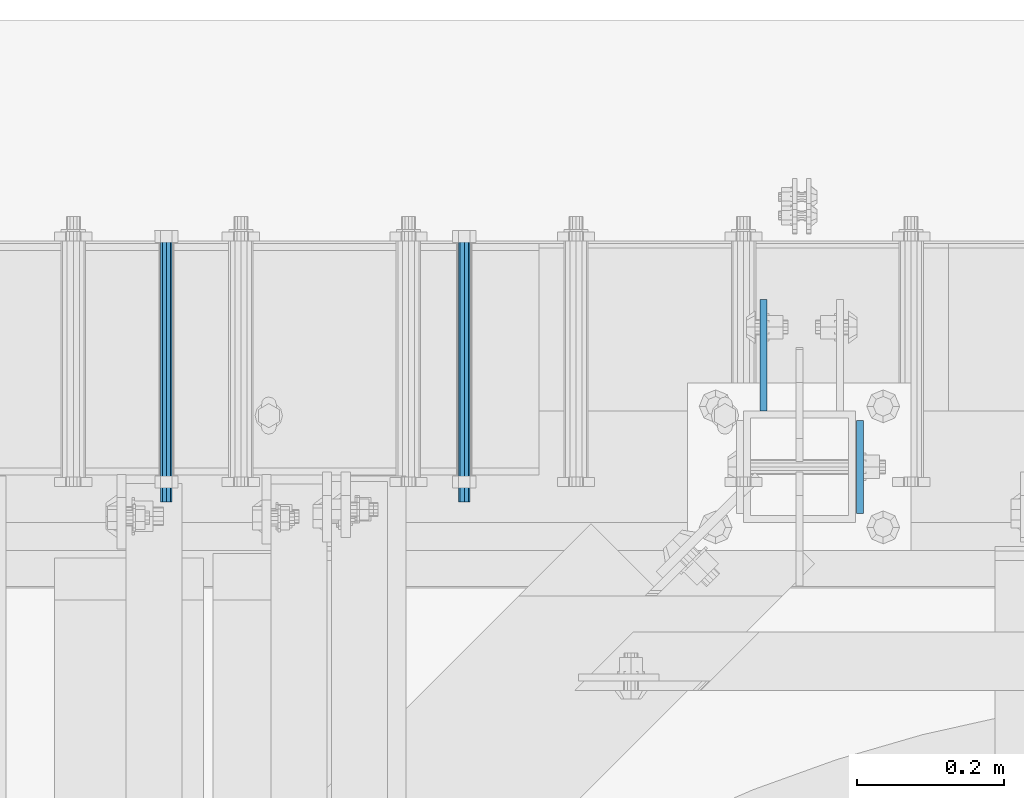
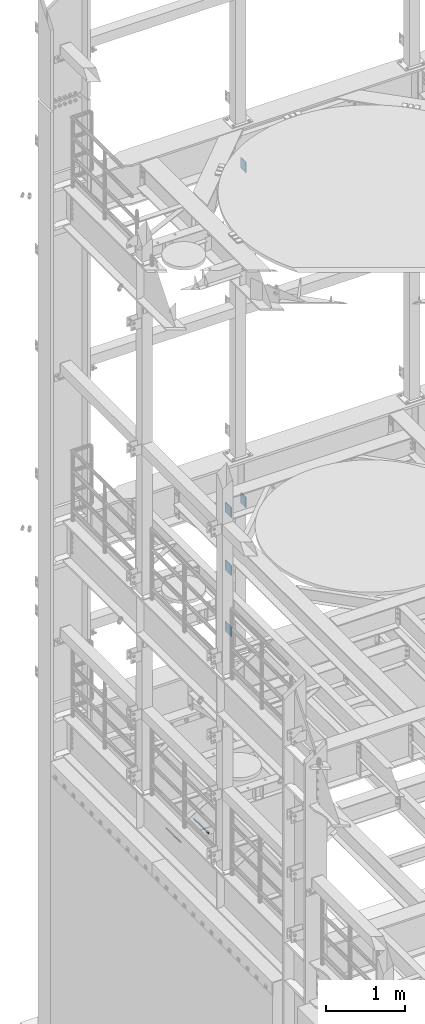
# One storey, part 1320 of 1876: 7 beams, 5 elements without a shape of their own.
"""IFC2X3 building model written with IfcOpenShell, lengths in millimetres."""

import ifcopenshell
import ifcopenshell.guid

model = None  # the IFC model being written
_history = None  # IfcOwnerHistory: only IFC2X3 demands one
_inside = {}  # id of a spatial element -> (the spatial element, [elements in it])
_under = {}  # id of a project, library or spatial element -> (it, [spatial elements below it])
_declared = {}  # id of a project -> (the project, [libraries it declares])
_typed = {}  # id of a type object -> (the type object, [elements of that type])
_made_of = {}  # id of a material, layer set ... -> (it, [elements and type objects made of it])


def new_model(schema):
    """Start an empty IFC model of exactly this schema.

    Asked for "IFC4X3", IfcOpenShell would pick the latest addendum, in which some entities
    have other attributes; the version numbers below select the first issue.
    IFC2X3 requires an IfcOwnerHistory on every rooted entity: one is made here for all.
    """
    global model, _history
    if schema == "IFC4X3":
        model = ifcopenshell.file(schema_version=(4, 3, 0, 0))
    else:
        model = ifcopenshell.file(schema=schema)
    _inside.clear()
    _under.clear()
    _declared.clear()
    _typed.clear()
    _made_of.clear()
    _history = None
    if model.schema == "IFC2X3":
        org = make("IfcOrganization", Name="unknown")
        user = make(
            "IfcPersonAndOrganization",
            ThePerson=make("IfcPerson", FamilyName="unknown"),
            TheOrganization=org,
        )
        app = make(
            "IfcApplication",
            ApplicationDeveloper=org,
            Version="unknown",
            ApplicationFullName="unknown",
            ApplicationIdentifier="unknown",
        )
        _history = make(
            "IfcOwnerHistory",
            OwningUser=user,
            OwningApplication=app,
            ChangeAction="ADDED",
            CreationDate=0,
        )
    return model


def make(cls, **values):
    """One entity of the class cls with the attributes given. An attribute that is None is left unset."""
    return model.create_entity(
        cls, **{name: value for name, value in values.items() if value is not None}
    )


def rooted(cls, **values):
    """An entity with a GlobalId (a new one), such as an element, a storey or a relation."""
    return make(cls, GlobalId=ifcopenshell.guid.new(), OwnerHistory=_history, **values)


def si_unit(unit_type, name, prefix=None):
    """IfcSIUnit, for example si_unit("LENGTHUNIT", "METRE", prefix="MILLI")."""
    return make("IfcSIUnit", UnitType=unit_type, Prefix=prefix, Name=name)


def assignment(units):
    """IfcUnitAssignment: the units of a project."""
    return None if units is None else make("IfcUnitAssignment", Units=units)


def point(xyz):
    """IfcCartesianPoint."""
    return None if xyz is None else make("IfcCartesianPoint", Coordinates=xyz)


def direction(xyz):
    """IfcDirection."""
    return None if xyz is None else make("IfcDirection", DirectionRatios=xyz)


def frame(location, z_axis=None, x_axis=None):
    """IfcAxis2Placement3D, a coordinate frame: its origin and axes. An axis left out is left unset."""
    return make(
        "IfcAxis2Placement3D",
        Location=point(location),
        Axis=direction(z_axis),
        RefDirection=direction(x_axis),
    )


def origin_with_axes():
    """The frame at (0, 0, 0) with the z axis (0, 0, 1) and the x axis (1, 0, 0) written out."""
    return frame((0.0, 0.0, 0.0), z_axis=(0.0, 0.0, 1.0), x_axis=(1.0, 0.0, 0.0))


def place(relative_to, where):
    """IfcLocalPlacement: puts the frame where relative to a parent placement (None: the world)."""
    return make(
        "IfcLocalPlacement", PlacementRelTo=relative_to, RelativePlacement=where
    )


def context(
    kind, dimensions, precision=None, world=None, true_north=None, identifier=None
):
    """IfcGeometricRepresentationContext, for example the 3D "Model" context."""
    return make(
        "IfcGeometricRepresentationContext",
        ContextIdentifier=identifier,
        ContextType=kind,
        CoordinateSpaceDimension=dimensions,
        Precision=precision,
        WorldCoordinateSystem=world,
        TrueNorth=true_north,
    )


def subcontext(parent, identifier, kind, view, scale=None):
    """IfcGeometricRepresentationSubContext, for example "Body" below "Model"."""
    return make(
        "IfcGeometricRepresentationSubContext",
        ContextIdentifier=identifier,
        ContextType=kind,
        ParentContext=parent,
        TargetScale=scale,
        TargetView=view,
    )


def project(units=None, contexts=None):
    """IfcProject with its units and contexts."""
    return rooted(
        "IfcProject",
        Name="project",
        RepresentationContexts=contexts,
        UnitsInContext=assignment(units),
    )


def spatial(cls, under=None, at=None, **own):
    """A site, building, storey or space (cls), placed at a placement, below another one or the project."""
    s = rooted(cls, ObjectPlacement=at, **own)
    if under is not None:
        _under.setdefault(under.id(), (under, []))[1].append(s)
    return s


def faces_of(points, faces, orient=None, outer=None):
    """IfcFace entities. A face is a list of loops; a loop is a list of indices into points, from 0.

    orient and outer hold one flag for each loop. By default every Orientation is true, the
    first loop of a face is its IfcFaceOuterBound and the others are IfcFaceBound.
    """
    made = []
    for i, loops in enumerate(faces):
        bounds = []
        for j, loop in enumerate(loops):
            is_outer = j == 0 if outer is None else outer[i][j]
            bounds.append(
                make(
                    "IfcFaceOuterBound" if is_outer else "IfcFaceBound",
                    Bound=make("IfcPolyLoop", Polygon=[points[k] for k in loop]),
                    Orientation=True if orient is None else orient[i][j],
                )
            )
        made.append(make("IfcFace", Bounds=bounds))
    return made


def faceted_brep(points, faces, orient=None, outer=None, voids=None):
    """IfcFacetedBrep: a solid bounded by flat faces; with voids (closed shells), ...WithVoids."""
    shared = [point(p) for p in points]
    hull = make("IfcClosedShell", CfsFaces=faces_of(shared, faces, orient, outer))
    if voids is None:
        return make("IfcFacetedBrep", Outer=hull)
    return make(
        "IfcFacetedBrepWithVoids",
        Outer=hull,
        Voids=[
            make(cls, CfsFaces=faces_of(shared, fs, o, b)) for cls, fs, o, b in voids
        ],
    )


def shape(context_of_items, identifier, shape_type, items):
    """IfcShapeRepresentation: the items that make up one representation, for example the "Body"."""
    return make(
        "IfcShapeRepresentation",
        ContextOfItems=context_of_items,
        RepresentationIdentifier=identifier,
        RepresentationType=shape_type,
        Items=items,
    )


def material(Name=None, Category=None):
    """IfcMaterial."""
    return make("IfcMaterial", Name=Name, Category=Category)


def made_of(thing, what):
    """Note that an element or type object is made of a material, layer set ...; save() writes the relation."""
    if what is not None:
        _made_of.setdefault(what.id(), (what, []))[1].append(thing)
    return thing


def type_object(cls, material=None, **own):
    """A type object (cls), such as IfcWallType, which elements share."""
    return made_of(rooted(cls, **own), material)


def element(
    cls,
    number,
    at=None,
    inside=None,
    cuts=None,
    type_object=None,
    material=None,
    context=None,
    identifier="Body",
    shape_type=None,
    held_by="IfcProductDefinitionShape",
    body=None,
    shapes=None,
    **own,
):
    """One element of the class cls, such as IfcWall. Its Tag is "e" and its number.

    at: its placement. inside: the storey or other place that contains it. cuts: it is an
    opening in that element (IfcRelVoidsElement). A single representation is given by context,
    identifier, shape_type and body (its items); several are given by shapes. held_by: the class
    of the entity that holds the representations. save() writes the other relations.
    """
    e = rooted(cls, Tag="e%d" % number, ObjectPlacement=at, **own)
    if body is not None:
        shapes = [shape(context, identifier, shape_type, body)]
    if shapes is not None:
        e.Representation = make(held_by, Representations=shapes)
    if inside is not None:
        _inside.setdefault(inside.id(), (inside, []))[1].append(e)
    if cuts is not None:
        rooted(
            "IfcRelVoidsElement", RelatingBuildingElement=cuts, RelatedOpeningElement=e
        )
    if type_object is not None:
        _typed.setdefault(type_object.id(), (type_object, []))[1].append(e)
    return made_of(e, material)


def aggregate(whole, parts):
    """IfcRelAggregates: a whole, such as a stair, and the parts it consists of."""
    return rooted("IfcRelAggregates", RelatingObject=whole, RelatedObjects=parts)


def save(model, path):
    """Write the relations noted so far, then the file.

    IfcRelAggregates (storeys below a building ...), IfcRelContainedInSpatialStructure (elements
    in a storey), IfcRelDefinesByType, IfcRelAssociatesMaterial and IfcRelDeclares: one each for
    every whole, place, type object, material and project.
    """
    for whole, parts in _under.values():
        aggregate(whole, parts)
    for where, things in _inside.values():
        rooted(
            "IfcRelContainedInSpatialStructure",
            RelatedElements=things,
            RelatingStructure=where,
        )
    for kind, things in _typed.values():
        rooted("IfcRelDefinesByType", RelatedObjects=things, RelatingType=kind)
    for what, things in _made_of.values():
        rooted("IfcRelAssociatesMaterial", RelatedObjects=things, RelatingMaterial=what)
    for by, libraries in _declared.values():
        rooted("IfcRelDeclares", RelatingContext=by, RelatedDefinitions=libraries)
    model.write(path)


model = new_model("IFC2X3")

# Units and contexts
model_context = context("Model", 3, precision=1e-05, world=origin_with_axes())
body_context = subcontext(model_context, "Body", "Model", "MODEL_VIEW")
ifc_project = project(units=[si_unit("LENGTHUNIT", "METRE", prefix="MILLI"), si_unit("AREAUNIT", "SQUARE_METRE"), si_unit("VOLUMEUNIT", "CUBIC_METRE"), si_unit("MASSUNIT", "GRAM", prefix="KILO"), si_unit("TIMEUNIT", "SECOND"), si_unit("PLANEANGLEUNIT", "RADIAN"), si_unit("SOLIDANGLEUNIT", "STERADIAN"), si_unit("THERMODYNAMICTEMPERATUREUNIT", "DEGREE_CELSIUS"), si_unit("LUMINOUSINTENSITYUNIT", "LUMEN")], contexts=[model_context])

# Site, building, storey
site_placement = place(None, origin_with_axes())
site = spatial("IfcSite", under=ifc_project, at=site_placement, CompositionType="ELEMENT")
building_placement = place(site_placement, origin_with_axes())
building = spatial("IfcBuilding", under=site, at=building_placement, Name="Undefined", CompositionType="ELEMENT")
storey_placement = place(building_placement, origin_with_axes())
storey = spatial("IfcBuildingStorey", under=building, at=storey_placement, Name="Undefined", CompositionType="ELEMENT", Elevation=0.0)

# Assembly, beams
assembly_1_placement = place(storey_placement, origin_with_axes())
assembly_1 = element("IfcElementAssembly", 1, at=assembly_1_placement, inside=storey, Name="FRAME", AssemblyPlace="NOTDEFINED", PredefinedType="RIGID_FRAME")
ifc_material = material(Name="STEEL/A36")
beam_type_1 = type_object("IfcBeamType", PredefinedType="NOTDEFINED")
beam_1_placement = place(assembly_1_placement, frame((2490.7762944527, 13792.2, 7226.3), z_axis=(0.0, 0.0, -1.0), x_axis=(0.0, 1.0, 0.0)))
beam_1 = element("IfcBeam", 2, at=beam_1_placement, type_object=beam_type_1, material=ifc_material, Name="PLATE", context=body_context, shape_type="Brep", body=[
    faceted_brep([(0.0, 4.76249999999982, -76.1999999999998), (3.63797880709171e-12, 4.76249999999982, 76.1999969482422), (152.399993896484, 4.76250000000073, 76.1999969482422), (152.4, 4.76249999999982, -76.1999999999998), (3.63797880709171e-12, -4.76249999999982, 76.1999969482422), (152.399993896484, -4.76250000000073, 76.1999969482422), (0.0, -4.76249999999982, -76.1999999999998), (152.4, -4.76249999999982, -76.1999999999998)], [[[0, 1, 2, 3]], [[4, 5, 2, 1]], [[4, 6, 7, 5]], [[6, 0, 3, 7]], [[5, 7, 3, 2]], [[6, 4, 1, 0]]]),
])
beam_2_placement = place(assembly_1_placement, frame((2490.7762944527, 13792.2, 6330.95), z_axis=(0.0, 0.0, -1.0), x_axis=(0.0, 1.0, 0.0)))
beam_2 = element("IfcBeam", 3, at=beam_2_placement, type_object=beam_type_1, material=ifc_material, Name="PLATE", context=body_context, shape_type="Brep", body=[
    faceted_brep([(0.0, 4.76249999999982, -76.1999999999998), (3.63797880709171e-12, 4.76249999999982, 76.1999969482422), (152.399993896484, 4.76250000000073, 76.1999969482422), (152.4, 4.76249999999982, -76.1999999999998), (3.63797880709171e-12, -4.76249999999982, 76.1999969482422), (152.399993896484, -4.76250000000073, 76.1999969482422), (0.0, -4.76249999999982, -76.1999999999998), (152.4, -4.76249999999982, -76.1999999999998)], [[[0, 1, 2, 3]], [[4, 5, 2, 1]], [[4, 6, 7, 5]], [[6, 0, 3, 7]], [[5, 7, 3, 2]], [[6, 4, 1, 0]]]),
])
beam_3_placement = place(assembly_1_placement, frame((2490.7762944527, 13792.2, 5384.8), z_axis=(0.0, 0.0, -1.0), x_axis=(0.0, 1.0, 0.0)))
beam_3 = element("IfcBeam", 4, at=beam_3_placement, type_object=beam_type_1, material=ifc_material, Name="PLATE", context=body_context, shape_type="Brep", body=[
    faceted_brep([(0.0, 4.76249999999982, -76.1999999999998), (3.63797880709171e-12, 4.76249999999982, 76.1999969482422), (152.399993896484, 4.76250000000073, 76.1999969482422), (152.4, 4.76249999999982, -76.1999999999998), (3.63797880709171e-12, -4.76249999999982, 76.1999969482422), (152.399993896484, -4.76250000000073, 76.1999969482422), (0.0, -4.76249999999982, -76.1999999999998), (152.4, -4.76249999999982, -76.1999999999998)], [[[0, 1, 2, 3]], [[4, 5, 2, 1]], [[4, 6, 7, 5]], [[6, 0, 3, 7]], [[5, 7, 3, 2]], [[6, 4, 1, 0]]]),
])
aggregate(assembly_1, [beam_1, beam_2, beam_3])

# Assembly, beam
assembly_2_placement = place(storey_placement, origin_with_axes())
assembly_2 = element("IfcElementAssembly", 5, at=assembly_2_placement, inside=storey, Name="BEAM", AssemblyPlace="NOTDEFINED", PredefinedType="RIGID_FRAME")
beam_type_2 = type_object("IfcBeamType", PredefinedType="NOTDEFINED")
beam_4_placement = place(assembly_2_placement, frame((2622.55, 13779.5, 7423.15), z_axis=(0.0, 0.0, -1.0), x_axis=(0.0, -1.0, 0.0)))
beam_4 = element("IfcBeam", 6, at=beam_4_placement, type_object=beam_type_2, material=ifc_material, Name="PLATE", context=body_context, shape_type="Brep", body=[
    faceted_brep([(0.0, 4.76249999999982, -82.5499999999993), (0.0, 4.76249999999982, 82.5499999999993), (127.0, 4.76249999999982, 82.5499999999993), (127.0, 4.76249999999982, -82.5499999999993), (0.0, -4.76249999999982, 82.5499999999993), (127.0, -4.76249999999982, 82.5499999999993), (0.0, -4.76249999999982, -82.5499999999993), (127.0, -4.76249999999982, -82.5499999999993)], [[[0, 1, 2, 3]], [[1, 4, 5, 2]], [[4, 6, 7, 5]], [[6, 0, 3, 7]], [[5, 7, 3, 2]], [[6, 4, 1, 0]]]),
])
aggregate(assembly_2, [beam_4])

assembly_3_placement = place(storey_placement, origin_with_axes())
assembly_3 = element("IfcElementAssembly", 7, at=assembly_3_placement, inside=storey, Name="BEAM", AssemblyPlace="NOTDEFINED", PredefinedType="RIGID_FRAME")
beam_5_placement = place(assembly_3_placement, frame((2622.55, 13779.5, 12598.4), z_axis=(0.0, 0.0, -1.0), x_axis=(0.0, -1.0, 0.0)))
beam_5 = element("IfcBeam", 8, at=beam_5_placement, type_object=beam_type_2, material=ifc_material, Name="PLATE", context=body_context, shape_type="Brep", body=[
    faceted_brep([(0.0, 4.76249999999982, -82.5499999999993), (0.0, 4.76249999999982, 82.5499999999993), (127.0, 4.76249999999982, 82.5499999999993), (127.0, 4.76249999999982, -82.5499999999993), (0.0, -4.76249999999982, 82.5499999999993), (127.0, -4.76249999999982, 82.5499999999993), (0.0, -4.76249999999982, -82.5499999999993), (127.0, -4.76249999999982, -82.5499999999993)], [[[0, 1, 2, 3]], [[1, 4, 5, 2]], [[4, 6, 7, 5]], [[6, 0, 3, 7]], [[5, 7, 3, 2]], [[6, 4, 1, 0]]]),
])
aggregate(assembly_3, [beam_5])

assembly_4_placement = place(storey_placement, origin_with_axes())
assembly_4 = element("IfcElementAssembly", 9, at=assembly_4_placement, inside=storey, Name="ANCHOR_BOLT", AssemblyPlace="NOTDEFINED", PredefinedType="RIGID_FRAME")
beam_type_3 = type_object("IfcBeamType", PredefinedType="NOTDEFINED")
beam_6_placement = place(assembly_4_placement, frame((1676.40979190826, 13668.3750030189, 2493.96240234375), z_axis=(0.0, 0.0, 1.0), x_axis=(-2.91149999876944e-05, 0.999999999576158, 0.0)))
beam_6 = element("IfcBeam", 10, at=beam_6_placement, type_object=beam_type_3, material=ifc_material, Name="ANCHOR_BOLT", context=body_context, shape_type="Brep", body=[
    faceted_brep([(0.0, -7.9375, 0.0), (0.0, -5.61266007566822, -5.61266007566883), (369.887490732475, -5.61266007567792, -5.61266007566837), (369.887490732477, -7.93750000000978, 0.0), (0.0, 0.0, -7.9375), (369.88749073247, -9.54969436861575e-12, -7.9375), (0.0, 5.61266007566822, -5.61266007566883), (369.887490732464, 5.6126600756586, -5.61266007566837), (0.0, 7.9375, 0.0), (369.887490732463, 7.93749999999045, 0.0), (0.0, 5.61266007566822, 5.61266007566883), (369.887490732464, 5.6126600756586, 5.61266007566837), (0.0, 0.0, 7.9375), (369.88749073247, -9.54969436861575e-12, 7.9375), (0.0, -5.61266007566822, 5.61266007566883), (369.887490732475, -5.61266007567792, 5.61266007566837)], [[[0, 1, 2, 3]], [[1, 4, 5, 2]], [[4, 6, 7, 5]], [[6, 8, 9, 7]], [[8, 10, 11, 9]], [[10, 12, 13, 11]], [[12, 14, 15, 13]], [[14, 0, 3, 15]], [[5, 7, 9, 11, 13, 15, 3, 2]], [[14, 12, 10, 8, 6, 4, 1, 0]]]),
])
aggregate(assembly_4, [beam_6])

assembly_5_placement = place(storey_placement, origin_with_axes())
assembly_5 = element("IfcElementAssembly", 11, at=assembly_5_placement, inside=storey, Name="ANCHOR_BOLT", AssemblyPlace="NOTDEFINED", PredefinedType="RIGID_FRAME")
beam_7_placement = place(assembly_5_placement, frame((2082.80979190826, 13668.3750030189, 2493.96240234375), z_axis=(0.0, 0.0, 1.0), x_axis=(-2.91149999876944e-05, 0.999999999576158, 0.0)))
beam_7 = element("IfcBeam", 12, at=beam_7_placement, type_object=beam_type_3, material=ifc_material, Name="ANCHOR_BOLT", context=body_context, shape_type="Brep", body=[
    faceted_brep([(0.0, -7.9375, 0.0), (0.0, -5.61266007566822, -5.61266007566883), (369.887490732475, -5.61266007567792, -5.61266007566837), (369.887490732477, -7.93750000000978, 0.0), (0.0, 0.0, -7.9375), (369.88749073247, -9.54969436861575e-12, -7.9375), (0.0, 5.61266007566822, -5.61266007566883), (369.887490732464, 5.6126600756586, -5.61266007566837), (0.0, 7.9375, 0.0), (369.887490732463, 7.93749999999045, 0.0), (0.0, 5.61266007566822, 5.61266007566883), (369.887490732464, 5.6126600756586, 5.61266007566837), (0.0, 0.0, 7.9375), (369.88749073247, -9.54969436861575e-12, 7.9375), (0.0, -5.61266007566822, 5.61266007566883), (369.887490732475, -5.61266007567792, 5.61266007566837)], [[[0, 1, 2, 3]], [[1, 4, 5, 2]], [[4, 6, 7, 5]], [[6, 8, 9, 7]], [[8, 10, 11, 9]], [[10, 12, 13, 11]], [[12, 14, 15, 13]], [[14, 0, 3, 15]], [[5, 7, 9, 11, 13, 15, 3, 2]], [[14, 12, 10, 8, 6, 4, 1, 0]]]),
])
aggregate(assembly_5, [beam_7])

save(model, "model.ifc")
